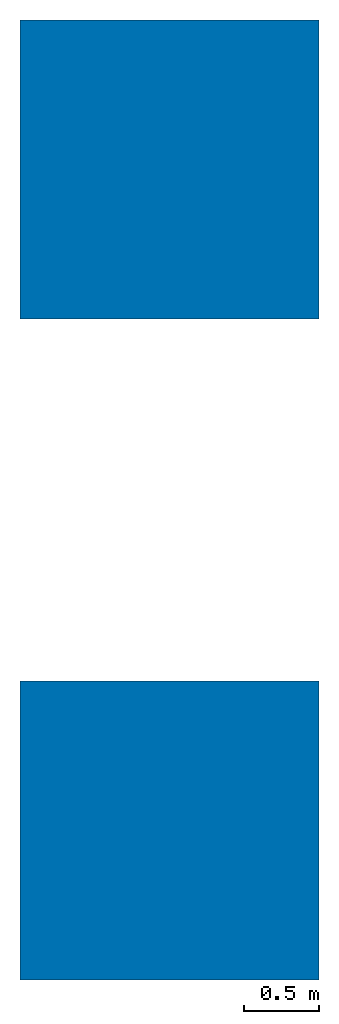
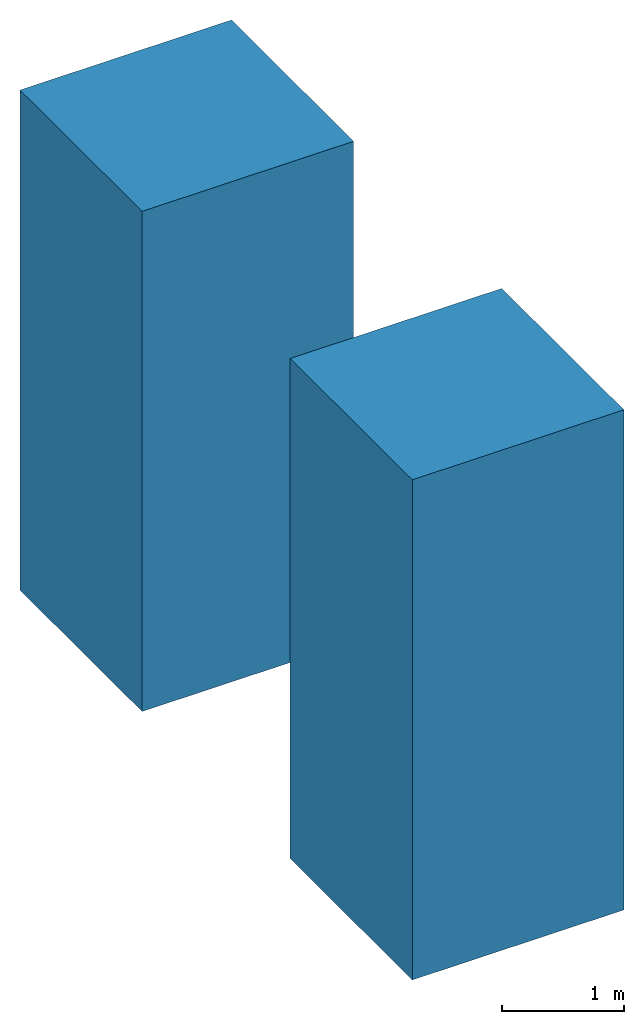
# Not in any storey: 2 walls.
"""IFC4 building model written with IfcOpenShell, lengths in metres."""

from ifc_helpers import new_model, entity, si_unit, converted_unit, direction, frame, frame_2d, origin_with_axes, place, context, subcontext, project, spatial, rectangle, extrude, source, transform, mapped, material, element, save


model = new_model("IFC4")

# Units and contexts
model_context = context("Model", 3, precision=1e-05, world=origin_with_axes(), true_north=direction((0.0, 1.0)))
body_context = subcontext(model_context, "Body", "Model", "MODEL_VIEW")
ifc_project = project(units=[si_unit("LENGTHUNIT", "METRE"), si_unit("AREAUNIT", "SQUARE_METRE"), si_unit("VOLUMEUNIT", "CUBIC_METRE"), converted_unit("PLANEANGLEUNIT", "DEGREE", entity("IfcPlaneAngleMeasure", 0.017453292519943295), si_unit("PLANEANGLEUNIT", "RADIAN"), dimensions=[0, 0, 0, 0, 0, 0, 0])], contexts=[model_context])

# Building
building = spatial("IfcBuilding", under=ifc_project, Name="Default Building", CompositionType="ELEMENT")

# Walls
ifc_material = material(Name="Material")
shared_shape = source(origin_with_axes(), body_context, "Body", "SweptSolid", [
    extrude(rectangle(XDim=2.0000000152588, YDim=2.0000000152588, at=frame_2d((0.0, 0.0), x_axis=(2.22044603230964e-16, 1.0))), frame((2.27373675443232e-16, -2.27373675443232e-16, -1.0000000076294), z_axis=(0.0, 0.0, 1.0), x_axis=(1.0, 0.0, 0.0)), (-2.75335308006397e-17, 1.11322149798365e-15, 1.0), 5.0),
])
placement = place(None, origin_with_axes())
element("IfcWall", 1, at=placement, inside=building, material=ifc_material, Name="Cube", PredefinedType="NOTDEFINED", context=body_context, shape_type="MappedRepresentation", body=[
    mapped(shared_shape, transform((0.0, 0.0, 0.0), x_axis=(1.0, 0.0, 0.0), y_axis=(0.0, 1.0, 0.0), z_axis=(0.0, 0.0, 1.0), scale=1.0)),
])
element("IfcWall", 2, at=placement, inside=building, material=ifc_material, Name="Cube.001", PredefinedType="NOTDEFINED", context=body_context, shape_type="MappedRepresentation", body=[
    mapped(shared_shape, transform((2.67266606386826e-17, 4.42543077468872, 3.967285065446e-15), x_axis=(1.0, 0.0, 0.0), y_axis=(0.0, 1.0, 0.0), z_axis=(0.0, 0.0, 1.0), scale=1.0)),
])

save(model, "model.ifc")
